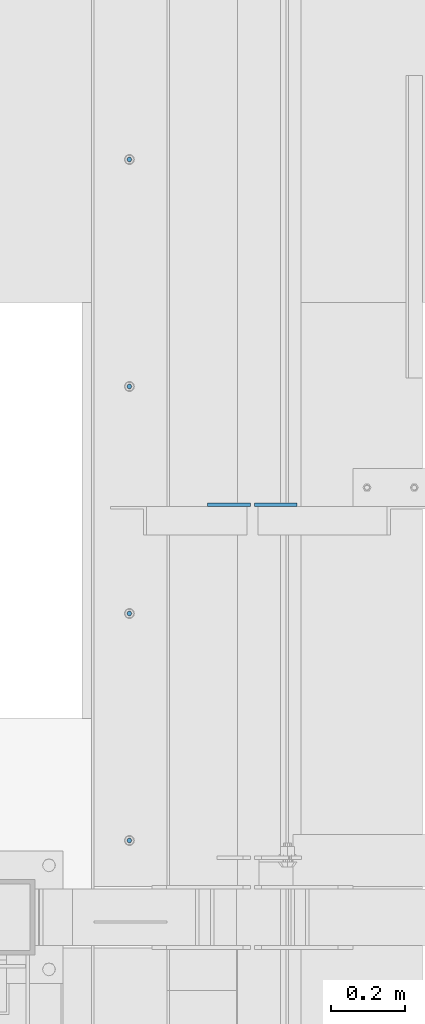
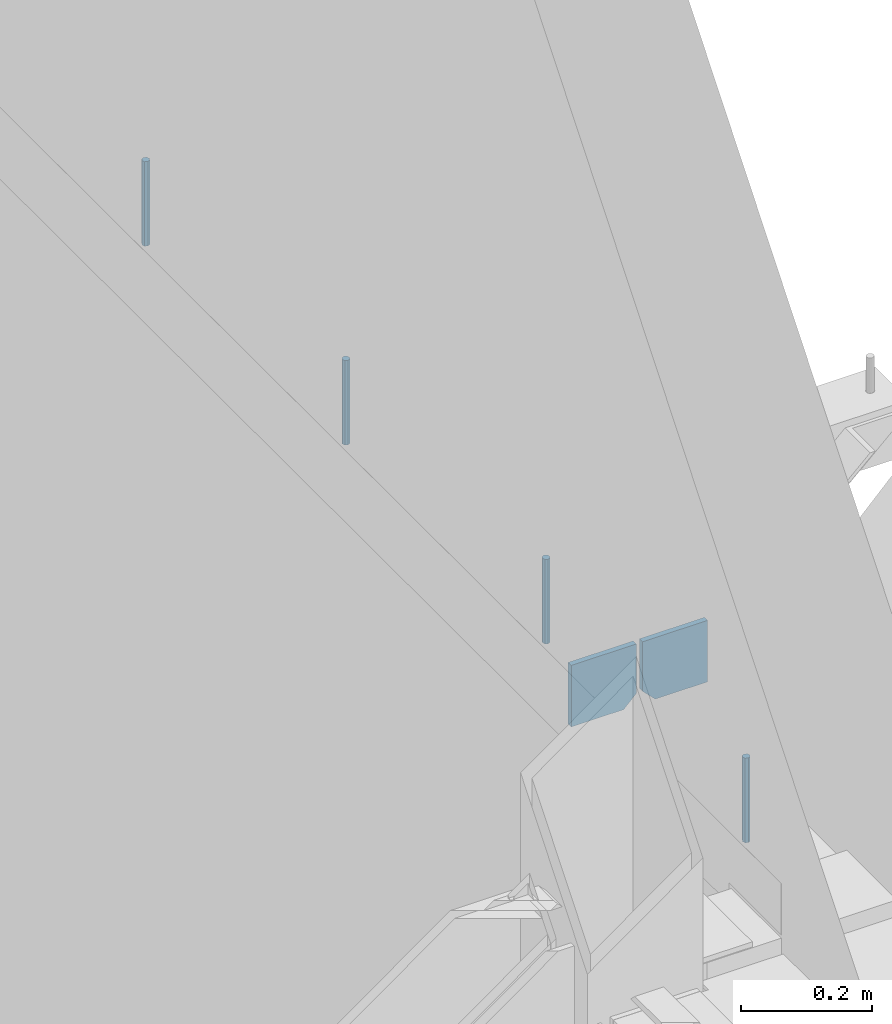
# One storey, part 498 of 1179: 6 columns, 1 element without a shape of its own.
"""IFC2X3 building model written with IfcOpenShell, lengths in millimetres."""

import ifcopenshell
import ifcopenshell.guid

model = None  # the IFC model being written
_history = None  # IfcOwnerHistory: only IFC2X3 demands one
_inside = {}  # id of a spatial element -> (the spatial element, [elements in it])
_under = {}  # id of a project, library or spatial element -> (it, [spatial elements below it])
_declared = {}  # id of a project -> (the project, [libraries it declares])
_typed = {}  # id of a type object -> (the type object, [elements of that type])
_made_of = {}  # id of a material, layer set ... -> (it, [elements and type objects made of it])


def new_model(schema):
    """Start an empty IFC model of exactly this schema.

    Asked for "IFC4X3", IfcOpenShell would pick the latest addendum, in which some entities
    have other attributes; the version numbers below select the first issue.
    IFC2X3 requires an IfcOwnerHistory on every rooted entity: one is made here for all.
    """
    global model, _history
    if schema == "IFC4X3":
        model = ifcopenshell.file(schema_version=(4, 3, 0, 0))
    else:
        model = ifcopenshell.file(schema=schema)
    _inside.clear()
    _under.clear()
    _declared.clear()
    _typed.clear()
    _made_of.clear()
    _history = None
    if model.schema == "IFC2X3":
        org = make("IfcOrganization", Name="unknown")
        user = make(
            "IfcPersonAndOrganization",
            ThePerson=make("IfcPerson", FamilyName="unknown"),
            TheOrganization=org,
        )
        app = make(
            "IfcApplication",
            ApplicationDeveloper=org,
            Version="unknown",
            ApplicationFullName="unknown",
            ApplicationIdentifier="unknown",
        )
        _history = make(
            "IfcOwnerHistory",
            OwningUser=user,
            OwningApplication=app,
            ChangeAction="ADDED",
            CreationDate=0,
        )
    return model


def make(cls, **values):
    """One entity of the class cls with the attributes given. An attribute that is None is left unset."""
    return model.create_entity(
        cls, **{name: value for name, value in values.items() if value is not None}
    )


def rooted(cls, **values):
    """An entity with a GlobalId (a new one), such as an element, a storey or a relation."""
    return make(cls, GlobalId=ifcopenshell.guid.new(), OwnerHistory=_history, **values)


def si_unit(unit_type, name, prefix=None):
    """IfcSIUnit, for example si_unit("LENGTHUNIT", "METRE", prefix="MILLI")."""
    return make("IfcSIUnit", UnitType=unit_type, Prefix=prefix, Name=name)


def assignment(units):
    """IfcUnitAssignment: the units of a project."""
    return None if units is None else make("IfcUnitAssignment", Units=units)


def point(xyz):
    """IfcCartesianPoint."""
    return None if xyz is None else make("IfcCartesianPoint", Coordinates=xyz)


def direction(xyz):
    """IfcDirection."""
    return None if xyz is None else make("IfcDirection", DirectionRatios=xyz)


def frame(location, z_axis=None, x_axis=None):
    """IfcAxis2Placement3D, a coordinate frame: its origin and axes. An axis left out is left unset."""
    return make(
        "IfcAxis2Placement3D",
        Location=point(location),
        Axis=direction(z_axis),
        RefDirection=direction(x_axis),
    )


def origin_with_axes():
    """The frame at (0, 0, 0) with the z axis (0, 0, 1) and the x axis (1, 0, 0) written out."""
    return frame((0.0, 0.0, 0.0), z_axis=(0.0, 0.0, 1.0), x_axis=(1.0, 0.0, 0.0))


def place(relative_to, where):
    """IfcLocalPlacement: puts the frame where relative to a parent placement (None: the world)."""
    return make(
        "IfcLocalPlacement", PlacementRelTo=relative_to, RelativePlacement=where
    )


def context(
    kind, dimensions, precision=None, world=None, true_north=None, identifier=None
):
    """IfcGeometricRepresentationContext, for example the 3D "Model" context."""
    return make(
        "IfcGeometricRepresentationContext",
        ContextIdentifier=identifier,
        ContextType=kind,
        CoordinateSpaceDimension=dimensions,
        Precision=precision,
        WorldCoordinateSystem=world,
        TrueNorth=true_north,
    )


def subcontext(parent, identifier, kind, view, scale=None):
    """IfcGeometricRepresentationSubContext, for example "Body" below "Model"."""
    return make(
        "IfcGeometricRepresentationSubContext",
        ContextIdentifier=identifier,
        ContextType=kind,
        ParentContext=parent,
        TargetScale=scale,
        TargetView=view,
    )


def project(units=None, contexts=None):
    """IfcProject with its units and contexts."""
    return rooted(
        "IfcProject",
        Name="project",
        RepresentationContexts=contexts,
        UnitsInContext=assignment(units),
    )


def spatial(cls, under=None, at=None, **own):
    """A site, building, storey or space (cls), placed at a placement, below another one or the project."""
    s = rooted(cls, ObjectPlacement=at, **own)
    if under is not None:
        _under.setdefault(under.id(), (under, []))[1].append(s)
    return s


def faces_of(points, faces, orient=None, outer=None):
    """IfcFace entities. A face is a list of loops; a loop is a list of indices into points, from 0.

    orient and outer hold one flag for each loop. By default every Orientation is true, the
    first loop of a face is its IfcFaceOuterBound and the others are IfcFaceBound.
    """
    made = []
    for i, loops in enumerate(faces):
        bounds = []
        for j, loop in enumerate(loops):
            is_outer = j == 0 if outer is None else outer[i][j]
            bounds.append(
                make(
                    "IfcFaceOuterBound" if is_outer else "IfcFaceBound",
                    Bound=make("IfcPolyLoop", Polygon=[points[k] for k in loop]),
                    Orientation=True if orient is None else orient[i][j],
                )
            )
        made.append(make("IfcFace", Bounds=bounds))
    return made


def faceted_brep(points, faces, orient=None, outer=None, voids=None):
    """IfcFacetedBrep: a solid bounded by flat faces; with voids (closed shells), ...WithVoids."""
    shared = [point(p) for p in points]
    hull = make("IfcClosedShell", CfsFaces=faces_of(shared, faces, orient, outer))
    if voids is None:
        return make("IfcFacetedBrep", Outer=hull)
    return make(
        "IfcFacetedBrepWithVoids",
        Outer=hull,
        Voids=[
            make(cls, CfsFaces=faces_of(shared, fs, o, b)) for cls, fs, o, b in voids
        ],
    )


def shape(context_of_items, identifier, shape_type, items):
    """IfcShapeRepresentation: the items that make up one representation, for example the "Body"."""
    return make(
        "IfcShapeRepresentation",
        ContextOfItems=context_of_items,
        RepresentationIdentifier=identifier,
        RepresentationType=shape_type,
        Items=items,
    )


def material(Name=None, Category=None):
    """IfcMaterial."""
    return make("IfcMaterial", Name=Name, Category=Category)


def made_of(thing, what):
    """Note that an element or type object is made of a material, layer set ...; save() writes the relation."""
    if what is not None:
        _made_of.setdefault(what.id(), (what, []))[1].append(thing)
    return thing


def type_object(cls, material=None, **own):
    """A type object (cls), such as IfcWallType, which elements share."""
    return made_of(rooted(cls, **own), material)


def element(
    cls,
    number,
    at=None,
    inside=None,
    cuts=None,
    type_object=None,
    material=None,
    context=None,
    identifier="Body",
    shape_type=None,
    held_by="IfcProductDefinitionShape",
    body=None,
    shapes=None,
    **own,
):
    """One element of the class cls, such as IfcWall. Its Tag is "e" and its number.

    at: its placement. inside: the storey or other place that contains it. cuts: it is an
    opening in that element (IfcRelVoidsElement). A single representation is given by context,
    identifier, shape_type and body (its items); several are given by shapes. held_by: the class
    of the entity that holds the representations. save() writes the other relations.
    """
    e = rooted(cls, Tag="e%d" % number, ObjectPlacement=at, **own)
    if body is not None:
        shapes = [shape(context, identifier, shape_type, body)]
    if shapes is not None:
        e.Representation = make(held_by, Representations=shapes)
    if inside is not None:
        _inside.setdefault(inside.id(), (inside, []))[1].append(e)
    if cuts is not None:
        rooted(
            "IfcRelVoidsElement", RelatingBuildingElement=cuts, RelatedOpeningElement=e
        )
    if type_object is not None:
        _typed.setdefault(type_object.id(), (type_object, []))[1].append(e)
    return made_of(e, material)


def aggregate(whole, parts):
    """IfcRelAggregates: a whole, such as a stair, and the parts it consists of."""
    return rooted("IfcRelAggregates", RelatingObject=whole, RelatedObjects=parts)


def save(model, path):
    """Write the relations noted so far, then the file.

    IfcRelAggregates (storeys below a building ...), IfcRelContainedInSpatialStructure (elements
    in a storey), IfcRelDefinesByType, IfcRelAssociatesMaterial and IfcRelDeclares: one each for
    every whole, place, type object, material and project.
    """
    for whole, parts in _under.values():
        aggregate(whole, parts)
    for where, things in _inside.values():
        rooted(
            "IfcRelContainedInSpatialStructure",
            RelatedElements=things,
            RelatingStructure=where,
        )
    for kind, things in _typed.values():
        rooted("IfcRelDefinesByType", RelatedObjects=things, RelatingType=kind)
    for what, things in _made_of.values():
        rooted("IfcRelAssociatesMaterial", RelatedObjects=things, RelatingMaterial=what)
    for by, libraries in _declared.values():
        rooted("IfcRelDeclares", RelatingContext=by, RelatedDefinitions=libraries)
    model.write(path)


model = new_model("IFC2X3")

# Units and contexts
model_context = context("Model", 3, precision=1e-05, world=origin_with_axes())
body_context = subcontext(model_context, "Body", "Model", "MODEL_VIEW")
ifc_project = project(units=[si_unit("LENGTHUNIT", "METRE", prefix="MILLI"), si_unit("AREAUNIT", "SQUARE_METRE"), si_unit("VOLUMEUNIT", "CUBIC_METRE"), si_unit("MASSUNIT", "GRAM", prefix="KILO"), si_unit("TIMEUNIT", "SECOND"), si_unit("PLANEANGLEUNIT", "RADIAN"), si_unit("SOLIDANGLEUNIT", "STERADIAN"), si_unit("THERMODYNAMICTEMPERATUREUNIT", "DEGREE_CELSIUS"), si_unit("LUMINOUSINTENSITYUNIT", "LUMEN")], contexts=[model_context])

# Site, building, storey
site_placement = place(None, origin_with_axes())
site = spatial("IfcSite", under=ifc_project, at=site_placement, CompositionType="ELEMENT")
building_placement = place(site_placement, origin_with_axes())
building = spatial("IfcBuilding", under=site, at=building_placement, Name="Undefined", CompositionType="ELEMENT")
storey_placement = place(building_placement, origin_with_axes())
storey = spatial("IfcBuildingStorey", under=building, at=storey_placement, Name="Undefined", CompositionType="ELEMENT", Elevation=0.0)

# Assembly, columns
assembly_placement = place(storey_placement, origin_with_axes())
assembly = element("IfcElementAssembly", 1, at=assembly_placement, inside=storey, Name="BEAM", AssemblyPlace="NOTDEFINED", PredefinedType="RIGID_FRAME")
ifc_material_1 = material(Name="STEEL/A36")
column_type_1 = type_object("IfcColumnType", PredefinedType="NOTDEFINED")
column_1_placement = place(assembly_placement, frame((494.506249999995, 38750.875, 3702.05), z_axis=(-1.0, 0.0, 0.0), x_axis=(0.0, 0.0, 1.0)))
column_1 = element("IfcColumn", 2, at=column_1_placement, type_object=column_type_1, material=ifc_material_1, Name="PLATE", context=body_context, shape_type="Brep", body=[
    faceted_brep([(22.2250000000004, 4.76250000000073, 57.1500000000015), (0.0, 4.76250000000073, 34.9249999999993), (0.0, -4.76250000000073, 34.9249999999993), (22.2250000000004, -4.76250000000073, 57.1500000000015), (114.300000000001, 4.76250000000073, 57.1500000000015), (114.300000000001, 4.76250000000073, -57.1500000000015), (0.0, 4.76250000000073, -57.1500000000015), (114.300000000001, -4.76250000000073, 57.1500000000015), (0.0, -4.76250000000073, -57.1500000000015), (114.300000000001, -4.76250000000073, -57.1500000000015)], [[[0, 1, 2, 3]], [[4, 5, 6, 1, 0]], [[7, 4, 0, 3]], [[8, 9, 7, 3, 2]], [[8, 6, 5, 9]], [[7, 9, 5, 4]], [[6, 8, 2, 1]]]),
])
column_2_placement = place(assembly_placement, frame((369.09375, 38750.875, 3702.05), z_axis=(1.0, 0.0, 0.0), x_axis=(0.0, 0.0, 1.0)))
column_2 = element("IfcColumn", 3, at=column_2_placement, type_object=column_type_1, material=ifc_material_1, Name="PLATE", context=body_context, shape_type="Brep", body=[
    faceted_brep([(22.2250000000004, 4.76250000000073, 57.1500000000015), (0.0, 4.76250000000073, 34.9249999999993), (0.0, -4.76250000000073, 34.9249999999993), (22.2250000000004, -4.76250000000073, 57.1500000000015), (114.300000000001, 4.76250000000073, 57.1500000000015), (114.300000000001, 4.76250000000073, -57.1500000000015), (0.0, 4.76250000000073, -57.1500000000015), (114.300000000001, -4.76250000000073, 57.1500000000015), (0.0, -4.76250000000073, -57.1500000000015), (114.300000000001, -4.76250000000073, -57.1500000000015)], [[[0, 1, 2, 3]], [[4, 5, 6, 1, 0]], [[7, 4, 0, 3]], [[8, 9, 7, 3, 2]], [[8, 6, 5, 9]], [[7, 9, 5, 4]], [[6, 8, 2, 1]]]),
])
ifc_material_2 = material(Name="STEEL/A307")
column_type_2 = type_object("IfcColumnType", PredefinedType="NOTDEFINED")
column_3_placement = place(assembly_placement, frame((101.600000006011, 39677.9749988592, 4108.45), z_axis=(0.0, 1.0, 0.0), x_axis=(0.0, 0.0, 1.0)))
column_3 = element("IfcColumn", 4, at=column_3_placement, type_object=column_type_2, material=ifc_material_2, Name="THREADED ROD", context=body_context, shape_type="Brep", body=[
    faceted_brep([(0.0, -6.34999999999854, 0.0), (0.0, -4.49012806053361, -4.49012806053452), (157.162499999999, -4.49012806053361, -4.49012806053361), (157.162499999999, -6.34999999999854, 0.0), (0.0, 0.0, -6.34999999999991), (157.162499999999, 0.0, -6.34999999999854), (0.0, 4.49012806053361, -4.49012806053452), (157.162499999999, 4.49012806053361, -4.49012806053361), (0.0, 6.34999999999854, 0.0), (157.162499999999, 6.34999999999854, 0.0), (0.0, 4.49012806053361, 4.49012806053452), (157.162499999999, 4.49012806053361, 4.49012806053361), (0.0, 0.0, 6.34999999999991), (157.162499999999, 0.0, 6.34999999999854), (0.0, -4.49012806053361, 4.49012806053452), (157.162499999999, -4.49012806053361, 4.49012806053361)], [[[0, 1, 2, 3]], [[1, 4, 5, 2]], [[4, 6, 7, 5]], [[6, 8, 9, 7]], [[8, 10, 11, 9]], [[10, 12, 13, 11]], [[12, 14, 15, 13]], [[14, 0, 3, 15]], [[5, 7, 9, 11, 13, 15, 3, 2]], [[14, 12, 10, 8, 6, 4, 1, 0]]]),
])
column_4_placement = place(assembly_placement, frame((101.600000006011, 39068.3749988592, 4108.45), z_axis=(0.0, 1.0, 0.0), x_axis=(0.0, 0.0, 1.0)))
column_4 = element("IfcColumn", 5, at=column_4_placement, type_object=column_type_2, material=ifc_material_2, Name="THREADED ROD", context=body_context, shape_type="Brep", body=[
    faceted_brep([(0.0, -6.34999999999854, 0.0), (0.0, -4.49012806053361, -4.49012806053452), (157.162499999999, -4.49012806053361, -4.49012806053361), (157.162499999999, -6.34999999999854, 0.0), (0.0, 0.0, -6.34999999999991), (157.162499999999, 0.0, -6.34999999999854), (0.0, 4.49012806053361, -4.49012806053452), (157.162499999999, 4.49012806053361, -4.49012806053361), (0.0, 6.34999999999854, 0.0), (157.162499999999, 6.34999999999854, 0.0), (0.0, 4.49012806053361, 4.49012806053452), (157.162499999999, 4.49012806053361, 4.49012806053361), (0.0, 0.0, 6.34999999999991), (157.162499999999, 0.0, 6.34999999999854), (0.0, -4.49012806053361, 4.49012806053452), (157.162499999999, -4.49012806053361, 4.49012806053361)], [[[0, 1, 2, 3]], [[1, 4, 5, 2]], [[4, 6, 7, 5]], [[6, 8, 9, 7]], [[8, 10, 11, 9]], [[10, 12, 13, 11]], [[12, 14, 15, 13]], [[14, 0, 3, 15]], [[5, 7, 9, 11, 13, 15, 3, 2]], [[14, 12, 10, 8, 6, 4, 1, 0]]]),
])
column_5_placement = place(assembly_placement, frame((101.600000006011, 38458.7749988592, 4108.45), z_axis=(0.0, 1.0, 0.0), x_axis=(0.0, 0.0, 1.0)))
column_5 = element("IfcColumn", 6, at=column_5_placement, type_object=column_type_2, material=ifc_material_2, Name="THREADED ROD", context=body_context, shape_type="Brep", body=[
    faceted_brep([(0.0, -6.34999999999854, 0.0), (0.0, -4.49012806053361, -4.49012806053452), (157.162499999999, -4.49012806053361, -4.49012806053361), (157.162499999999, -6.34999999999854, 0.0), (0.0, 0.0, -6.34999999999991), (157.162499999999, 0.0, -6.34999999999854), (0.0, 4.49012806053361, -4.49012806053452), (157.162499999999, 4.49012806053361, -4.49012806053361), (0.0, 6.34999999999854, 0.0), (157.162499999999, 6.34999999999854, 0.0), (0.0, 4.49012806053361, 4.49012806053452), (157.162499999999, 4.49012806053361, 4.49012806053361), (0.0, 0.0, 6.34999999999991), (157.162499999999, 0.0, 6.34999999999854), (0.0, -4.49012806053361, 4.49012806053452), (157.162499999999, -4.49012806053361, 4.49012806053361)], [[[0, 1, 2, 3]], [[1, 4, 5, 2]], [[4, 6, 7, 5]], [[6, 8, 9, 7]], [[8, 10, 11, 9]], [[10, 12, 13, 11]], [[12, 14, 15, 13]], [[14, 0, 3, 15]], [[5, 7, 9, 11, 13, 15, 3, 2]], [[14, 12, 10, 8, 6, 4, 1, 0]]]),
])
column_6_placement = place(assembly_placement, frame((101.600000006011, 37849.1749988592, 4108.45), z_axis=(0.0, 1.0, 0.0), x_axis=(0.0, 0.0, 1.0)))
column_6 = element("IfcColumn", 7, at=column_6_placement, type_object=column_type_2, material=ifc_material_2, Name="THREADED ROD", context=body_context, shape_type="Brep", body=[
    faceted_brep([(0.0, -6.34999999999854, 0.0), (0.0, -4.49012806053361, -4.49012806053452), (157.162499999999, -4.49012806053361, -4.49012806053361), (157.162499999999, -6.34999999999854, 0.0), (0.0, 0.0, -6.34999999999991), (157.162499999999, 0.0, -6.34999999999854), (0.0, 4.49012806053361, -4.49012806053452), (157.162499999999, 4.49012806053361, -4.49012806053361), (0.0, 6.34999999999854, 0.0), (157.162499999999, 6.34999999999854, 0.0), (0.0, 4.49012806053361, 4.49012806053452), (157.162499999999, 4.49012806053361, 4.49012806053361), (0.0, 0.0, 6.34999999999991), (157.162499999999, 0.0, 6.34999999999854), (0.0, -4.49012806053361, 4.49012806053452), (157.162499999999, -4.49012806053361, 4.49012806053361)], [[[0, 1, 2, 3]], [[1, 4, 5, 2]], [[4, 6, 7, 5]], [[6, 8, 9, 7]], [[8, 10, 11, 9]], [[10, 12, 13, 11]], [[12, 14, 15, 13]], [[14, 0, 3, 15]], [[5, 7, 9, 11, 13, 15, 3, 2]], [[14, 12, 10, 8, 6, 4, 1, 0]]]),
])
aggregate(assembly, [column_1, column_2, column_3, column_4, column_5, column_6])

save(model, "model.ifc")
